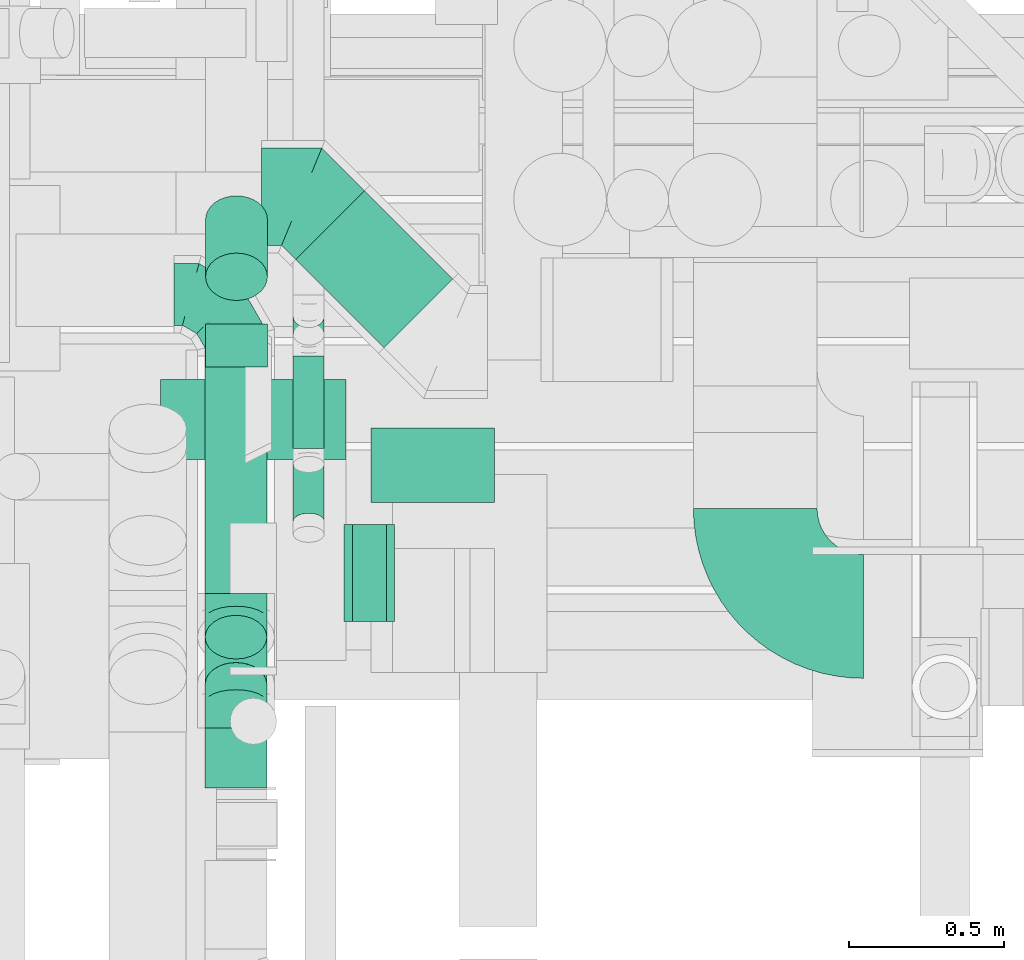
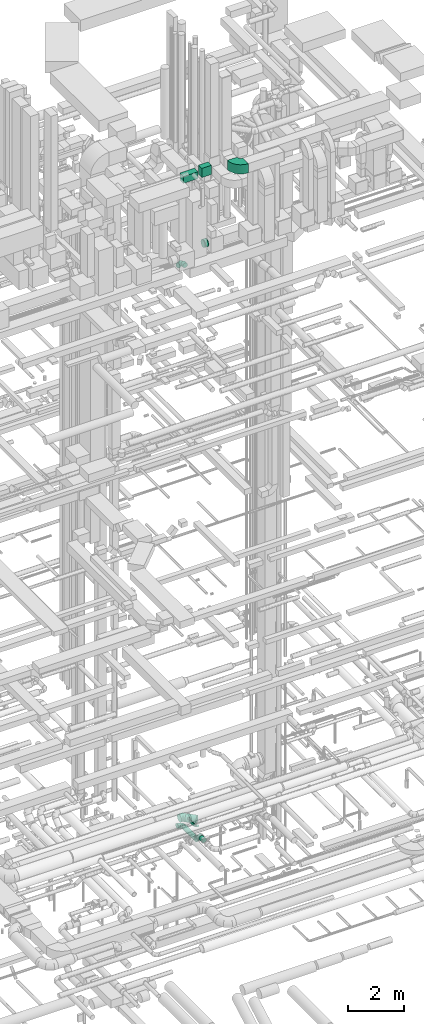
# One storey, part 220 of 337: 12 flow segments, 7 flow fittings.
"""IFC2X3 building model written with IfcOpenShell, lengths in millimetres."""

from ifc_helpers import new_model, entity, si_unit, converted_unit, derived_unit, direction, frame, frame_2d, origin, origin_2d_with_axis, place, context, subcontext, project, spatial, polyline, circle_curve, parameter, trimmed, segment, composite_curve, rectangle, circle, outline, extrude, faceted_brep, source, transform, mapped, material, type_object, type_shapes, element, save


model = new_model("IFC2X3")

# Units and contexts
model_context = context("Model", 3, precision=0.01, world=origin(), true_north=direction((6.12303176911189e-17, 1.0)))
body_context = subcontext(model_context, "Body", "Model", "MODEL_VIEW")
ifc_project = project(units=[si_unit("LENGTHUNIT", "METRE", prefix="MILLI"), si_unit("AREAUNIT", "SQUARE_METRE"), si_unit("VOLUMEUNIT", "CUBIC_METRE"), converted_unit("PLANEANGLEUNIT", "DEGREE", entity("IfcRatioMeasure", 0.0174532925199433), si_unit("PLANEANGLEUNIT", "RADIAN"), dimensions=[0, 0, 0, 0, 0, 0, 0]), si_unit("MASSUNIT", "GRAM", prefix="KILO"), derived_unit("MASSDENSITYUNIT", [(si_unit("MASSUNIT", "GRAM", prefix="KILO"), 1), (si_unit("LENGTHUNIT", "METRE"), -3)]), derived_unit("MOMENTOFINERTIAUNIT", [(si_unit("LENGTHUNIT", "METRE"), 4)]), si_unit("TIMEUNIT", "SECOND"), si_unit("FREQUENCYUNIT", "HERTZ"), si_unit("THERMODYNAMICTEMPERATUREUNIT", "DEGREE_CELSIUS"), derived_unit("THERMALTRANSMITTANCEUNIT", [(si_unit("MASSUNIT", "GRAM", prefix="KILO"), 1), (si_unit("THERMODYNAMICTEMPERATUREUNIT", "KELVIN"), -1), (si_unit("TIMEUNIT", "SECOND"), -3)]), derived_unit("VOLUMETRICFLOWRATEUNIT", [(si_unit("LENGTHUNIT", "METRE"), 3), (si_unit("TIMEUNIT", "SECOND"), -1)]), derived_unit("MASSFLOWRATEUNIT", [(si_unit("MASSUNIT", "GRAM", prefix="KILO"), 1), (si_unit("TIMEUNIT", "SECOND"), -1)]), derived_unit("ROTATIONALFREQUENCYUNIT", [(si_unit("TIMEUNIT", "SECOND"), -1)]), si_unit("ELECTRICCURRENTUNIT", "AMPERE"), si_unit("ELECTRICVOLTAGEUNIT", "VOLT"), si_unit("POWERUNIT", "WATT"), si_unit("FORCEUNIT", "NEWTON", prefix="KILO"), si_unit("ILLUMINANCEUNIT", "LUX"), si_unit("LUMINOUSFLUXUNIT", "LUMEN"), si_unit("LUMINOUSINTENSITYUNIT", "CANDELA"), derived_unit("USERDEFINED", [(si_unit("MASSUNIT", "GRAM", prefix="KILO"), -1), (si_unit("LENGTHUNIT", "METRE"), -2), (si_unit("TIMEUNIT", "SECOND"), 3), (si_unit("LUMINOUSFLUXUNIT", "LUMEN"), 1)]), derived_unit("LINEARVELOCITYUNIT", [(si_unit("LENGTHUNIT", "METRE"), 1), (si_unit("TIMEUNIT", "SECOND"), -1)]), si_unit("PRESSUREUNIT", "PASCAL"), derived_unit("USERDEFINED", [(si_unit("LENGTHUNIT", "METRE"), -2), (si_unit("MASSUNIT", "GRAM", prefix="KILO"), 1), (si_unit("TIMEUNIT", "SECOND"), -2)]), derived_unit("LINEARFORCEUNIT", [(si_unit("MASSUNIT", "GRAM", prefix="KILO"), 1), (si_unit("LENGTHUNIT", "METRE"), 1), (si_unit("TIMEUNIT", "SECOND"), -2), (si_unit("LENGTHUNIT", "METRE"), -1)]), derived_unit("PLANARFORCEUNIT", [(si_unit("MASSUNIT", "GRAM", prefix="KILO"), 1), (si_unit("LENGTHUNIT", "METRE"), 1), (si_unit("TIMEUNIT", "SECOND"), -2), (si_unit("LENGTHUNIT", "METRE"), -2)])], contexts=[model_context])

# Site, building, storey
site_placement = place(None, origin())
site = spatial("IfcSite", under=ifc_project, at=site_placement, CompositionType="ELEMENT")
building_placement = place(site_placement, origin())
building = spatial("IfcBuilding", under=site, at=building_placement, CompositionType="ELEMENT")
storey_placement = place(building_placement, origin())
storey = spatial("IfcBuildingStorey", under=building, at=storey_placement, CompositionType="ELEMENT", Elevation=0.0)

# Flow segments
duct_segment_type_1 = type_object("IfcDuctSegmentType", PredefinedType="NOTDEFINED")
flow_segment_1_placement = place(storey_placement, frame((54088.0, 8895.5, 31400.0)))
element("IfcFlowSegment", 1, at=flow_segment_1_placement, inside=storey, type_object=duct_segment_type_1, context=body_context, shape_type="SweptSolid", body=[
    extrude(rectangle(XDim=260.000000000065, YDim=600.000000000002, at=origin_2d_with_axis()), frame((300.0, 130.0, 0.0), z_axis=(0.0, 0.0, 1.0), x_axis=(0.0, 1.0, 0.0)), (0.0, 0.0, 1.0), 300.000000000001),
])
flow_segment_2_placement = place(storey_placement, frame((54768.0, 8757.5, 31500.0)))
element("IfcFlowSegment", 2, at=flow_segment_2_placement, inside=storey, type_object=duct_segment_type_1, context=body_context, shape_type="SweptSolid", body=[
    extrude(rectangle(XDim=240.500000000089, YDim=399.999999999996, at=origin_2d_with_axis()), frame((200.0, 120.25, 0.0), z_axis=(0.0, 0.0, 1.0), x_axis=(0.0, 1.0, 0.0)), (0.0, 0.0, 1.0), 400.000000000004),
])
duct_segment_type_2 = type_object("IfcDuctSegmentType", PredefinedType="NOTDEFINED")
flow_segment_3_placement = place(storey_placement, frame((54230.32, 8462.9, 2948.4)))
element("IfcFlowSegment", 3, at=flow_segment_3_placement, inside=storey, type_object=duct_segment_type_2, context=body_context, shape_type="SweptSolid", body=[
    extrude(circle(Radius=100.0, at=origin_2d_with_axis()), frame((101.6, 0.0, 101.6), z_axis=(0.0, 1.0, 0.0), x_axis=(-1.0, 0.0, 0.0)), (0.0, 0.0, 1.0), 767.057287525357),
])
flow_segment_4_placement = place(storey_placement, frame((54230.32, 8096.33, 3036.27)))
element("IfcFlowSegment", 4, at=flow_segment_4_placement, inside=storey, type_object=duct_segment_type_2, context=body_context, shape_type="SweptSolid", body=[
    extrude(circle(Radius=100.0, at=origin_2d_with_axis()), frame((101.6, 225.15, 72.31), z_axis=(0.0, -0.707106781186546, 0.707106781186549), x_axis=(-1.0, 0.0, 0.0)), (0.0, 0.0, 1.0), 216.152236891493),
])
flow_segment_5_placement = place(storey_placement, frame((54231.92, 9408.69, 27205.57)))
element("IfcFlowSegment", 5, at=flow_segment_5_placement, inside=storey, type_object=duct_segment_type_2, context=body_context, shape_type="SweptSolid", body=[
    extrude(circle(Radius=100.0, at=origin_2d_with_axis()), frame((101.6, 78.2, 286.65), z_axis=(0.0, 0.642787609686537, -0.76604444311898), x_axis=(-1.0, 0.0, 0.0)), (0.0, 0.0, 1.0), 288.206572271396),
])
flow_segment_6_placement = place(storey_placement, frame((54231.92, 9194.98, 27462.07)))
element("IfcFlowSegment", 6, at=flow_segment_6_placement, inside=storey, type_object=duct_segment_type_2, context=body_context, shape_type="SweptSolid", body=[
    extrude(circle(Radius=100.0, at=origin_2d_with_axis()), frame((101.6, 0.0, 101.6), z_axis=(0.0, 1.0, 0.0), x_axis=(1.0, 0.0, 0.0)), (0.0, 0.0, 1.0), 138.700860216017),
])
flow_segment_7_placement = place(storey_placement, frame((54515.4, 8668.63, 3195.29)))
element("IfcFlowSegment", 7, at=flow_segment_7_placement, inside=storey, type_object=duct_segment_type_2, context=body_context, shape_type="SweptSolid", body=[
    extrude(circle(Radius=50.0, at=origin_2d_with_axis()), frame((51.6, 27.6, 156.26), z_axis=(0.0, 0.854088777418906, -0.520127253936071), x_axis=(1.0, 0.0, 0.0)), (0.0, 0.0, 1.0), 215.250588398526),
])
flow_segment_8_placement = place(storey_placement, frame((54523.65, 9255.18, 2940.91)))
element("IfcFlowSegment", 8, at=flow_segment_8_placement, inside=storey, type_object=duct_segment_type_2, context=body_context, shape_type="SweptSolid", body=[
    extrude(circle(Radius=157.5, at=origin_2d_with_axis()), frame((398.44, 112.96, 159.1), z_axis=(-0.707106781182107, 0.707106781190988, 0.0), x_axis=(-0.707106781190988, -0.707106781182107, 0.0)), (0.0, 0.0, 1.0), 403.72583002495),
])
flow_segment_9_placement = place(storey_placement, frame((54515.4, 8932.09, 3173.4)))
element("IfcFlowSegment", 9, at=flow_segment_9_placement, inside=storey, type_object=duct_segment_type_2, context=body_context, shape_type="SweptSolid", body=[
    extrude(circle(Radius=50.0, at=origin_2d_with_axis()), frame((51.6, 0.0, 51.6), z_axis=(0.0, 1.0, 0.0), x_axis=(1.0, 0.0, 0.0)), (0.0, 0.0, 1.0), 298.546772507563),
])
flow_segment_10_placement = place(storey_placement, frame((54515.4, 9264.39, 3217.34)))
element("IfcFlowSegment", 10, at=flow_segment_10_placement, inside=storey, type_object=duct_segment_type_2, context=body_context, shape_type="SweptSolid", body=[
    extrude(circle(Radius=50.0, at=origin_2d_with_axis()), frame((51.6, 36.95, 36.95), z_axis=(0.0, 0.70710616095761, 0.707107401414941), x_axis=(-1.0, 0.0, 0.0)), (0.0, 0.0, 1.0), 79.7910898784956),
])
flow_segment_11_placement = place(storey_placement, frame((54230.32, 7833.68, 3218.4)))
element("IfcFlowSegment", 11, at=flow_segment_11_placement, inside=storey, type_object=duct_segment_type_2, context=body_context, shape_type="SweptSolid", body=[
    extrude(circle(Radius=100.0, at=origin_2d_with_axis()), frame((101.6, 0.0, 101.6), z_axis=(0.0, 1.0, 0.0), x_axis=(1.0, 0.0, 0.0)), (0.0, 0.0, 1.0), 193.533487977303),
])
flow_segment_12_placement = place(storey_placement, frame((54708.0, 8369.87, 28635.9)))
element("IfcFlowSegment", 12, at=flow_segment_12_placement, inside=storey, type_object=duct_segment_type_2, context=body_context, shape_type="SweptSolid", body=[
    extrude(circle(Radius=157.5, at=origin_2d_with_axis()), frame((0.0, 159.1, 159.1), z_axis=(1.0, 0.0, 0.0), x_axis=(0.0, -1.0, 0.0)), (0.0, 0.0, 1.0), 110.000024999834),
])

# Flow fittings
ifc_material = material()
duct_fitting_type_1 = type_object("IfcDuctFittingType", PredefinedType="NOTDEFINED", material=ifc_material)
shared_shape_1 = source(origin(), body_context, "Body", "Brep", [
    faceted_brep([(-200.0, 0.0, -100.0), (-200.0, -25.88, -96.59), (-200.0, -50.0, -86.6), (-200.0, -70.71, -70.71), (-200.0, -86.6, -50.0), (-200.0, -96.59, -25.88), (-200.0, -100.0, 0.0), (-200.0, -96.59, 25.88), (-200.0, -86.6, 50.0), (-200.0, -70.71, 70.71), (-200.0, -50.0, 86.6), (-200.0, -25.88, 96.59), (-200.0, 0.0, 100.0), (-200.0, 25.88, 96.59), (-200.0, 50.0, 86.6), (-200.0, 70.71, 70.71), (-200.0, 86.6, 50.0), (-200.0, 96.59, 25.88), (-200.0, 100.0, 0.0), (-200.0, 96.59, -25.88), (-200.0, 86.6, -50.0), (-200.0, 70.71, -70.71), (-200.0, 50.0, -86.6), (-200.0, 25.88, -96.59), (-153.35, 25.88, 96.59), (-159.81, 50.0, 86.6), (-146.41, 0.0, 100.0), (-165.36, 70.71, 70.71), (-172.29, 96.59, 25.88), (-173.21, 100.0, 0.0), (-169.62, 86.6, 50.0), (-169.62, 86.6, -50.0), (-165.36, 70.71, -70.71), (-172.29, 96.59, -25.88), (-153.35, 25.88, -96.59), (-146.41, 0.0, -100.0), (-159.81, 50.0, -86.6), (-139.48, -25.88, -96.59), (-133.01, -50.0, -86.6), (-127.46, -70.71, -70.71), (-123.21, -86.6, -50.0), (-120.53, -96.59, -25.88), (-119.62, -100.0, 0.0), (-120.53, -96.59, 25.88), (-123.21, -86.6, 50.0), (-127.46, -70.71, 70.71), (-133.01, -50.0, 86.6), (-139.48, -25.88, 96.59), (-72.54, 72.54, 96.59), (-90.19, 90.19, 86.6), (-53.59, 53.59, 100.0), (-105.35, 105.35, 70.71), (-116.99, 116.99, 50.0), (-124.3, 124.3, 25.88), (-126.79, 126.79, 0.0), (-124.3, 124.3, -25.88), (-116.99, 116.99, -50.0), (-105.35, 105.35, -70.71), (-72.54, 72.54, -96.59), (-53.59, 53.59, -100.0), (-90.19, 90.19, -86.6), (-34.64, 34.64, -96.59), (-16.99, 16.99, -86.6), (-1.83, 1.83, -70.71), (9.81, -9.81, -50.0), (17.12, -17.12, -25.88), (19.62, -19.62, 0.0), (17.12, -17.12, 25.88), (9.81, -9.81, 50.0), (-1.83, 1.83, 70.71), (-16.99, 16.99, 86.6), (-34.64, 34.64, 96.59), (-25.88, 153.35, 96.59), (-50.0, 159.81, 86.6), (0.0, 146.41, 100.0), (-70.71, 165.36, 70.71), (-86.6, 169.62, 50.0), (-96.59, 172.29, 25.88), (-100.0, 173.21, 0.0), (-96.59, 172.29, -25.88), (-86.6, 169.62, -50.0), (-70.71, 165.36, -70.71), (-25.88, 153.35, -96.59), (0.0, 146.41, -100.0), (-50.0, 159.81, -86.6), (25.88, 139.48, -96.59), (50.0, 133.01, -86.6), (70.71, 127.46, -70.71), (86.6, 123.21, -50.0), (96.59, 120.53, -25.88), (100.0, 119.62, 0.0), (96.59, 120.53, 25.88), (86.6, 123.21, 50.0), (70.71, 127.46, 70.71), (50.0, 133.01, 86.6), (25.88, 139.48, 96.59), (-25.88, 200.0, -96.59), (-50.0, 200.0, -86.6), (-70.71, 200.0, -70.71), (-86.6, 200.0, -50.0), (-96.59, 200.0, -25.88), (-100.0, 200.0, 0.0), (-96.59, 200.0, 25.88), (-86.6, 200.0, 50.0), (-70.71, 200.0, 70.71), (-50.0, 200.0, 86.6), (-25.88, 200.0, 96.59), (0.0, 200.0, 100.0), (25.88, 200.0, 96.59), (50.0, 200.0, 86.6), (70.71, 200.0, 70.71), (86.6, 200.0, 50.0), (96.59, 200.0, 25.88), (100.0, 200.0, 0.0), (96.59, 200.0, -25.88), (86.6, 200.0, -50.0), (70.71, 200.0, -70.71), (50.0, 200.0, -86.6), (25.88, 200.0, -96.59), (0.0, 200.0, -100.0)], [[[0, 1, 2, 3, 4, 5, 6, 7, 8, 9, 10, 11, 12, 13, 14, 15, 16, 17, 18, 19, 20, 21, 22, 23]], [[24, 25, 14, 13]], [[26, 24, 13, 12]], [[14, 25, 27, 15]], [[28, 29, 18, 17]], [[30, 28, 17, 16]], [[15, 27, 30, 16]], [[20, 31, 32, 21]], [[33, 31, 20, 19]], [[18, 29, 33, 19]], [[34, 35, 0, 23]], [[36, 34, 23, 22]], [[32, 36, 22, 21]], [[1, 0, 35, 37]], [[2, 1, 37, 38]], [[38, 39, 3, 2]], [[5, 4, 40, 41]], [[6, 5, 41, 42]], [[39, 40, 4, 3]], [[6, 42, 43, 7]], [[7, 43, 44, 8]], [[8, 44, 45, 9]], [[9, 45, 46, 10]], [[10, 46, 47, 11]], [[26, 12, 11, 47]], [[48, 49, 25, 24]], [[50, 48, 24, 26]], [[27, 25, 49, 51]], [[52, 53, 28, 30]], [[51, 52, 30, 27]], [[29, 28, 53, 54]], [[55, 56, 31, 33]], [[54, 55, 33, 29]], [[32, 31, 56, 57]], [[58, 59, 35, 34]], [[60, 58, 34, 36]], [[57, 60, 36, 32]], [[37, 35, 59, 61]], [[38, 37, 61, 62]], [[39, 38, 62, 63]], [[41, 40, 64, 65]], [[42, 41, 65, 66]], [[63, 64, 40, 39]], [[43, 42, 66, 67]], [[44, 43, 67, 68]], [[68, 69, 45, 44]], [[46, 45, 69, 70]], [[47, 46, 70, 71]], [[26, 47, 71, 50]], [[72, 73, 49, 48]], [[74, 72, 48, 50]], [[51, 49, 73, 75]], [[76, 77, 53, 52]], [[75, 76, 52, 51]], [[54, 53, 77, 78]], [[79, 80, 56, 55]], [[78, 79, 55, 54]], [[57, 56, 80, 81]], [[82, 83, 59, 58]], [[84, 82, 58, 60]], [[81, 84, 60, 57]], [[61, 59, 83, 85]], [[62, 61, 85, 86]], [[63, 62, 86, 87]], [[65, 64, 88, 89]], [[66, 65, 89, 90]], [[87, 88, 64, 63]], [[67, 66, 90, 91]], [[68, 67, 91, 92]], [[92, 93, 69, 68]], [[70, 69, 93, 94]], [[71, 70, 94, 95]], [[50, 71, 95, 74]], [[96, 97, 98, 99, 100, 101, 102, 103, 104, 105, 106, 107, 108, 109, 110, 111, 112, 113, 114, 115, 116, 117, 118, 119]], [[72, 74, 107, 106]], [[73, 72, 106, 105]], [[75, 73, 105, 104]], [[102, 101, 78, 77]], [[103, 102, 77, 76]], [[75, 104, 103, 76]], [[78, 101, 100, 79]], [[79, 100, 99, 80]], [[80, 99, 98, 81]], [[84, 97, 96, 82]], [[82, 96, 119, 83]], [[84, 81, 98, 97]], [[118, 117, 86, 85]], [[119, 118, 85, 83]], [[116, 87, 86, 117]], [[88, 115, 114, 89]], [[89, 114, 113, 90]], [[115, 88, 87, 116]], [[91, 90, 113, 112]], [[92, 91, 112, 111]], [[111, 110, 93, 92]], [[95, 94, 109, 108]], [[74, 95, 108, 107]], [[110, 109, 94, 93]]]),
])
type_shapes(duct_fitting_type_1, [shared_shape_1])
flow_fitting_1_placement = place(storey_placement, frame((54331.91, 9429.95, 3050.0), z_axis=(0.0, 0.0, 1.0), x_axis=(0.0, 1.0, 0.0)))
element("IfcFlowFitting", 13, at=flow_fitting_1_placement, inside=storey, type_object=duct_fitting_type_1, material=ifc_material, context=body_context, shape_type="MappedRepresentation", body=[
    mapped(shared_shape_1, transform((0.0, 0.0, 0.0), scale=1.0)),
])
duct_fitting_type_2 = type_object("IfcDuctFittingType", PredefinedType="NOTDEFINED", material=ifc_material)
shared_shape_2 = source(origin(), body_context, "Body", "Brep", [
    faceted_brep([(-82.84, 0.0, -100.0), (-82.84, -25.88, -96.59), (-82.84, -50.0, -86.6), (-82.84, -70.71, -70.71), (-82.84, -86.6, -50.0), (-82.84, -96.59, -25.88), (-82.84, -100.0, 0.0), (-82.84, -96.59, 25.88), (-82.84, -86.6, 50.0), (-82.84, -70.71, 70.71), (-82.84, -50.0, 86.6), (-82.84, -25.88, 96.59), (-82.84, 0.0, 100.0), (-82.84, 25.88, 96.59), (-82.84, 50.0, 86.6), (-82.84, 70.71, 70.71), (-82.84, 86.6, 50.0), (-82.84, 96.59, 25.88), (-82.84, 100.0, 0.0), (-82.84, 96.59, -25.88), (-82.84, 86.6, -50.0), (-82.84, 70.71, -70.71), (-82.84, 50.0, -86.6), (-82.84, 25.88, -96.59), (-10.72, 25.88, 96.59), (-20.71, 50.0, 86.6), (0.0, 0.0, 100.0), (-29.29, 70.71, 70.71), (-35.87, 86.6, 50.0), (-40.01, 96.59, 25.88), (-41.42, 100.0, 0.0), (-40.01, 96.59, -25.88), (-35.87, 86.6, -50.0), (-29.29, 70.71, -70.71), (-10.72, 25.88, -96.59), (0.0, 0.0, -100.0), (-20.71, 50.0, -86.6), (10.72, -25.88, -96.59), (20.71, -50.0, -86.6), (29.29, -70.71, -70.71), (35.87, -86.6, -50.0), (40.01, -96.59, -25.88), (41.42, -100.0, 0.0), (40.01, -96.59, 25.88), (35.87, -86.6, 50.0), (29.29, -70.71, 70.71), (20.71, -50.0, 86.6), (10.72, -25.88, 96.59), (58.58, 58.58, 100.0), (40.28, 76.88, 96.59), (23.22, 93.93, 86.6), (8.58, 108.58, 70.71), (-2.66, 119.82, 50.0), (-9.72, 126.88, 25.88), (-12.13, 129.29, 0.0), (-9.72, 126.88, -25.88), (-2.66, 119.82, -50.0), (8.58, 108.58, -70.71), (23.22, 93.93, -86.6), (40.28, 76.88, -96.59), (58.58, 58.58, -100.0), (76.88, 40.28, -96.59), (93.93, 23.22, -86.6), (108.58, 8.58, -70.71), (119.82, -2.66, -50.0), (126.88, -9.72, -25.88), (129.29, -12.13, 0.0), (126.88, -9.72, 25.88), (119.82, -2.66, 50.0), (108.58, 8.58, 70.71), (93.93, 23.22, 86.6), (76.88, 40.28, 96.59)], [[[0, 1, 2, 3, 4, 5, 6, 7, 8, 9, 10, 11, 12, 13, 14, 15, 16, 17, 18, 19, 20, 21, 22, 23]], [[24, 25, 14, 13]], [[26, 24, 13, 12]], [[14, 25, 27, 15]], [[28, 29, 17, 16]], [[28, 16, 15, 27]], [[30, 18, 17, 29]], [[31, 32, 20, 19]], [[30, 31, 19, 18]], [[32, 33, 21, 20]], [[34, 35, 0, 23]], [[36, 34, 23, 22]], [[33, 36, 22, 21]], [[1, 0, 35, 37]], [[2, 1, 37, 38]], [[38, 39, 3, 2]], [[5, 4, 40, 41]], [[6, 5, 41, 42]], [[39, 40, 4, 3]], [[6, 42, 43, 7]], [[7, 43, 44, 8]], [[8, 44, 45, 9]], [[9, 45, 46, 10]], [[10, 46, 47, 11]], [[26, 12, 11, 47]], [[24, 26, 48, 49]], [[25, 24, 49, 50]], [[27, 25, 50, 51]], [[29, 28, 52, 53]], [[30, 29, 53, 54]], [[51, 52, 28, 27]], [[30, 54, 55, 31]], [[31, 55, 56, 32]], [[57, 33, 32, 56]], [[36, 58, 59, 34]], [[34, 59, 60, 35]], [[58, 36, 33, 57]], [[35, 60, 61, 37]], [[37, 61, 62, 38]], [[63, 39, 38, 62]], [[40, 64, 65, 41]], [[41, 65, 66, 42]], [[64, 40, 39, 63]], [[43, 42, 66, 67]], [[44, 43, 67, 68]], [[68, 69, 45, 44]], [[47, 46, 70, 71]], [[26, 47, 71, 48]], [[69, 70, 46, 45]], [[59, 58, 57, 56, 55, 54, 53, 52, 51, 50, 49, 48, 71, 70, 69, 68, 67, 66, 65, 64, 63, 62, 61, 60]]]),
])
type_shapes(duct_fitting_type_2, [shared_shape_2])
for number, where, z_axis, x_axis in (
    (14, (54331.91, 8380.05, 3050.0), (-1.0, 0.0, 0.0), (0.0, -1.0, 0.0)),
    (15, (54331.91, 8110.05, 3320.0), (1.0, 0.0, 0.0), (0.0, -0.707106781186546, 0.707106781186549)),
):
    element("IfcFlowFitting", number, at=place(storey_placement, frame(where, z_axis=z_axis, x_axis=x_axis)), inside=storey, type_object=duct_fitting_type_2, material=ifc_material, context=body_context, shape_type="MappedRepresentation", body=[
        mapped(shared_shape_2, transform((0.0, 0.0, 0.0), scale=1.0)),
    ])
duct_fitting_type_3 = type_object("IfcDuctFittingType", PredefinedType="NOTDEFINED", material=ifc_material)
shared_shape_3 = source(origin(), body_context, "Body", "Brep", [
    faceted_brep([(20.0, 40.76, -152.13), (20.0, 78.75, -136.4), (20.0, 111.37, -111.37), (20.0, 136.4, -78.75), (20.0, 152.13, -40.76), (20.0, 157.5, 0.0), (20.0, 152.13, 40.76), (20.0, 136.4, 78.75), (20.0, 111.37, 111.37), (20.0, 78.75, 136.4), (20.0, 40.76, 152.13), (20.0, 0.0, 157.5), (20.0, -40.76, 152.13), (20.0, -78.75, 136.4), (20.0, -111.37, 111.37), (20.0, -136.4, 78.75), (20.0, -152.13, 40.76), (20.0, -157.5, 0.0), (20.0, -152.13, -40.76), (20.0, -136.4, -78.75), (20.0, -111.37, -111.37), (20.0, -78.75, -136.4), (20.0, -40.76, -152.13), (20.0, 0.0, -157.5), (0.0, 0.0, 157.5), (0.0, 40.76, 152.13), (-6.1, 40.76, 152.13), (-6.1, 0.0, 157.5), (0.0, 78.75, 136.4), (-6.1, 78.75, 136.4), (0.0, 111.37, 111.37), (-6.1, 111.37, 111.37), (0.0, 136.4, 78.75), (0.0, 152.13, 40.76), (-6.1, 152.13, 40.76), (-6.1, 136.4, 78.75), (0.0, 157.5, 0.0), (-6.1, 157.5, 0.0), (0.0, 152.13, -40.76), (-6.1, 152.13, -40.76), (0.0, 136.4, -78.75), (-6.1, 136.4, -78.75), (0.0, 111.37, -111.37), (-6.1, 111.37, -111.37), (0.0, 0.0, -157.5), (-6.1, 0.0, -157.5), (-6.1, 40.76, -152.13), (0.0, 40.76, -152.13), (-6.1, 78.75, -136.4), (0.0, 78.75, -136.4), (0.0, -40.76, -152.13), (-6.1, -40.76, -152.13), (0.0, -78.75, -136.4), (-6.1, -78.75, -136.4), (0.0, -111.37, -111.37), (-6.1, -111.37, -111.37), (0.0, -136.4, -78.75), (0.0, -152.13, -40.76), (-6.1, -152.13, -40.76), (-6.1, -136.4, -78.75), (0.0, -157.5, 0.0), (-6.1, -157.5, 0.0), (0.0, -152.13, 40.76), (-6.1, -152.13, 40.76), (0.0, -136.4, 78.75), (-6.1, -136.4, 78.75), (0.0, -111.37, 111.37), (-6.1, -111.37, 111.37), (0.0, -78.75, 136.4), (0.0, -40.76, 152.13), (-6.1, -40.76, 152.13), (-6.1, -78.75, 136.4)], [[[0, 1, 2, 3, 4, 5, 6, 7, 8, 9, 10, 11, 12, 13, 14, 15, 16, 17, 18, 19, 20, 21, 22, 23]], [[24, 11, 10, 25, 26, 27]], [[25, 10, 9, 28, 29, 26]], [[28, 9, 8, 30, 31, 29]], [[32, 7, 6, 33, 34, 35]], [[33, 6, 5, 36, 37, 34]], [[30, 8, 7, 32, 35, 31]], [[36, 5, 4, 38, 39, 37]], [[38, 4, 3, 40, 41, 39]], [[40, 3, 2, 42, 43, 41]], [[0, 23, 44, 45, 46, 47]], [[1, 0, 47, 46, 48, 49]], [[49, 48, 43, 42, 2, 1]], [[44, 23, 22, 50, 51, 45]], [[50, 22, 21, 52, 53, 51]], [[52, 21, 20, 54, 55, 53]], [[56, 19, 18, 57, 58, 59]], [[57, 18, 17, 60, 61, 58]], [[54, 20, 19, 56, 59, 55]], [[60, 17, 16, 62, 63, 61]], [[62, 16, 15, 64, 65, 63]], [[64, 15, 14, 66, 67, 65]], [[68, 13, 12, 69, 70, 71]], [[69, 12, 11, 24, 27, 70]], [[66, 14, 13, 68, 71, 67]], [[45, 51, 53, 55, 59, 58, 61, 63, 65, 67, 71, 70, 27, 26, 29, 31, 35, 34, 37, 39, 41, 43, 48, 46]]]),
])
type_shapes(duct_fitting_type_3, [shared_shape_3])
flow_fitting_2_placement = place(storey_placement, frame((54688.0, 8528.96, 28795.0), z_axis=(0.0, -1.0, 0.0), x_axis=(1.0, 0.0, 0.0)))
element("IfcFlowFitting", 16, at=flow_fitting_2_placement, inside=storey, type_object=duct_fitting_type_3, material=ifc_material, context=body_context, shape_type="MappedRepresentation", body=[
    mapped(shared_shape_3, transform((0.0, 0.0, 0.0), scale=1.0)),
])
duct_fitting_type_4 = type_object("IfcDuctFittingType", PredefinedType="NOTDEFINED", material=ifc_material)
shared_shape_4 = source(origin(), body_context, "Body", "Brep", [
    faceted_brep([(-130.48, 0.0, -157.5), (-130.48, -40.76, -152.13), (-130.48, -78.75, -136.4), (-130.48, -111.37, -111.37), (-130.48, -136.4, -78.75), (-130.48, -152.13, -40.76), (-130.48, -157.5, 0.0), (-130.48, -152.13, 40.76), (-130.48, -136.4, 78.75), (-130.48, -111.37, 111.37), (-130.48, -78.75, 136.4), (-130.48, -40.76, 152.13), (-130.48, 0.0, 157.5), (-130.48, 40.76, 152.13), (-130.48, 78.75, 136.4), (-130.48, 111.37, 111.37), (-130.48, 136.4, 78.75), (-130.48, 152.13, 40.76), (-130.48, 157.5, 0.0), (-130.48, 152.13, -40.76), (-130.48, 136.4, -78.75), (-130.48, 111.37, -111.37), (-130.48, 78.75, -136.4), (-130.48, 40.76, -152.13), (-16.89, 40.76, 152.13), (-32.62, 78.75, 136.4), (0.0, 0.0, 157.5), (-46.13, 111.37, 111.37), (-63.02, 152.13, 40.76), (-65.24, 157.5, 0.0), (-56.5, 136.4, 78.75), (-56.5, 136.4, -78.75), (-46.13, 111.37, -111.37), (-63.02, 152.13, -40.76), (-16.89, 40.76, -152.13), (0.0, 0.0, -157.5), (-32.62, 78.75, -136.4), (16.89, -40.76, -152.13), (32.62, -78.75, -136.4), (46.13, -111.37, -111.37), (56.5, -136.4, -78.75), (63.02, -152.13, -40.76), (65.24, -157.5, 0.0), (63.02, -152.13, 40.76), (56.5, -136.4, 78.75), (46.13, -111.37, 111.37), (32.62, -78.75, 136.4), (16.89, -40.76, 152.13), (92.26, 92.26, 157.5), (63.44, 121.09, 152.13), (36.58, 147.95, 136.4), (13.51, 171.01, 111.37), (-4.19, 188.71, 78.75), (-15.31, 199.84, 40.76), (-19.11, 203.63, 0.0), (-15.31, 199.84, -40.76), (-4.19, 188.71, -78.75), (13.51, 171.01, -111.37), (36.58, 147.95, -136.4), (63.44, 121.09, -152.13), (92.26, 92.26, -157.5), (121.09, 63.44, -152.13), (147.95, 36.58, -136.4), (171.01, 13.51, -111.37), (188.71, -4.19, -78.75), (199.84, -15.31, -40.76), (203.63, -19.11, 0.0), (199.84, -15.31, 40.76), (188.71, -4.19, 78.75), (171.01, 13.51, 111.37), (147.95, 36.58, 136.4), (121.09, 63.44, 152.13)], [[[0, 1, 2, 3, 4, 5, 6, 7, 8, 9, 10, 11, 12, 13, 14, 15, 16, 17, 18, 19, 20, 21, 22, 23]], [[24, 25, 14, 13]], [[26, 24, 13, 12]], [[14, 25, 27, 15]], [[28, 29, 18, 17]], [[30, 28, 17, 16]], [[15, 27, 30, 16]], [[20, 31, 32, 21]], [[33, 31, 20, 19]], [[18, 29, 33, 19]], [[34, 35, 0, 23]], [[36, 34, 23, 22]], [[32, 36, 22, 21]], [[1, 0, 35, 37]], [[2, 1, 37, 38]], [[38, 39, 3, 2]], [[5, 4, 40, 41]], [[6, 5, 41, 42]], [[39, 40, 4, 3]], [[6, 42, 43, 7]], [[7, 43, 44, 8]], [[8, 44, 45, 9]], [[9, 45, 46, 10]], [[10, 46, 47, 11]], [[26, 12, 11, 47]], [[24, 26, 48, 49]], [[25, 24, 49, 50]], [[27, 25, 50, 51]], [[28, 30, 52, 53]], [[29, 28, 53, 54]], [[51, 52, 30, 27]], [[55, 56, 31, 33]], [[54, 55, 33, 29]], [[57, 32, 31, 56]], [[36, 58, 59, 34]], [[34, 59, 60, 35]], [[58, 36, 32, 57]], [[35, 60, 61, 37]], [[37, 61, 62, 38]], [[63, 39, 38, 62]], [[40, 64, 65, 41]], [[41, 65, 66, 42]], [[64, 40, 39, 63]], [[43, 42, 66, 67]], [[44, 43, 67, 68]], [[68, 69, 45, 44]], [[47, 46, 70, 71]], [[26, 47, 71, 48]], [[69, 70, 46, 45]], [[54, 53, 52, 51, 50, 49, 48, 71, 70, 69, 68, 67, 66, 65, 64, 63, 62, 61, 60, 59, 58, 57, 56, 55]]]),
])
type_shapes(duct_fitting_type_4, [shared_shape_4])
flow_fitting_3_placement = place(storey_placement, frame((54544.36, 9745.88, 3100.0), z_axis=(-8.92429004970765e-06, -8.92429004970765e-06, 1.0), x_axis=(-0.707106781186548, 0.707106781186548, 0.0)))
element("IfcFlowFitting", 17, at=flow_fitting_3_placement, inside=storey, type_object=duct_fitting_type_4, material=ifc_material, context=body_context, shape_type="MappedRepresentation", body=[
    mapped(shared_shape_4, transform((0.0, 0.0, 0.0), scale=1.0)),
])
duct_fitting_type_5 = type_object("IfcDuctFittingType", PredefinedType="NOTDEFINED", material=ifc_material)
shared_shape_5 = source(origin(), body_context, "Body", "Brep", [
    faceted_brep([(20.0, 0.0, -157.5), (20.0, 40.76, -152.13), (20.0, 78.75, -136.4), (20.0, 111.37, -111.37), (20.0, 136.4, -78.75), (20.0, 152.13, -40.76), (20.0, 157.5, 0.0), (20.0, 152.13, 40.76), (20.0, 136.4, 78.75), (20.0, 111.37, 111.37), (20.0, 78.75, 136.4), (20.0, 40.76, 152.13), (20.0, 0.0, 157.5), (20.0, -40.76, 152.13), (20.0, -78.75, 136.4), (20.0, -111.37, 111.37), (20.0, -136.4, 78.75), (20.0, -152.13, 40.76), (20.0, -157.5, 0.0), (20.0, -152.13, -40.76), (20.0, -136.4, -78.75), (20.0, -111.37, -111.37), (20.0, -78.75, -136.4), (20.0, -40.76, -152.13), (0.0, 0.0, 157.5), (-6.1, 0.0, 157.5), (-6.1, -40.76, 152.13), (0.0, -40.76, 152.13), (-6.1, -78.75, 136.4), (0.0, -78.75, 136.4), (0.0, -111.37, 111.37), (-6.1, -111.37, 111.37), (0.0, -136.4, 78.75), (-6.1, -136.4, 78.75), (-6.1, -152.13, 40.76), (0.0, -152.13, 40.76), (-6.1, -157.5, 0.0), (0.0, -157.5, 0.0), (-6.1, -152.13, -40.76), (0.0, -152.13, -40.76), (-6.1, -136.4, -78.75), (0.0, -136.4, -78.75), (0.0, -111.37, -111.37), (-6.1, -111.37, -111.37), (0.0, 0.0, -157.5), (0.0, -40.76, -152.13), (-6.1, -40.76, -152.13), (-6.1, 0.0, -157.5), (0.0, -78.75, -136.4), (-6.1, -78.75, -136.4), (-6.1, 40.76, -152.13), (0.0, 40.76, -152.13), (-6.1, 78.75, -136.4), (0.0, 78.75, -136.4), (0.0, 111.37, -111.37), (-6.1, 111.37, -111.37), (0.0, 136.4, -78.75), (-6.1, 136.4, -78.75), (-6.1, 152.13, -40.76), (0.0, 152.13, -40.76), (-6.1, 157.5, 0.0), (0.0, 157.5, 0.0), (-6.1, 152.13, 40.76), (0.0, 152.13, 40.76), (-6.1, 136.4, 78.75), (0.0, 136.4, 78.75), (0.0, 111.37, 111.37), (-6.1, 111.37, 111.37), (0.0, 78.75, 136.4), (-6.1, 78.75, 136.4), (-6.1, 40.76, 152.13), (0.0, 40.76, 152.13)], [[[0, 1, 2, 3, 4, 5, 6, 7, 8, 9, 10, 11, 12, 13, 14, 15, 16, 17, 18, 19, 20, 21, 22, 23]], [[13, 12, 24, 25, 26, 27]], [[14, 13, 27, 26, 28, 29]], [[30, 15, 14, 29, 28, 31]], [[17, 16, 32, 33, 34, 35]], [[18, 17, 35, 34, 36, 37]], [[32, 16, 15, 30, 31, 33]], [[19, 18, 37, 36, 38, 39]], [[20, 19, 39, 38, 40, 41]], [[42, 21, 20, 41, 40, 43]], [[44, 0, 23, 45, 46, 47]], [[48, 49, 46, 45, 23, 22]], [[22, 21, 42, 43, 49, 48]], [[1, 0, 44, 47, 50, 51]], [[2, 1, 51, 50, 52, 53]], [[54, 3, 2, 53, 52, 55]], [[5, 4, 56, 57, 58, 59]], [[6, 5, 59, 58, 60, 61]], [[56, 4, 3, 54, 55, 57]], [[7, 6, 61, 60, 62, 63]], [[8, 7, 63, 62, 64, 65]], [[66, 9, 8, 65, 64, 67]], [[11, 10, 68, 69, 70, 71]], [[12, 11, 71, 70, 25, 24]], [[68, 10, 9, 66, 67, 69]], [[46, 49, 43, 40, 38, 36, 34, 33, 31, 28, 26, 25, 70, 69, 67, 64, 62, 60, 58, 57, 55, 52, 50, 47]]]),
])
type_shapes(duct_fitting_type_5, [shared_shape_5])
flow_fitting_4_placement = place(storey_placement, frame((54838.0, 8528.96, 28795.0), z_axis=(0.0, 0.0, -1.0), x_axis=(-1.0, 0.0, 0.0)))
element("IfcFlowFitting", 18, at=flow_fitting_4_placement, inside=storey, type_object=duct_fitting_type_5, material=ifc_material, context=body_context, shape_type="MappedRepresentation", body=[
    mapped(shared_shape_5, transform((0.0, 0.0, 0.0), scale=1.0)),
])
duct_fitting_type_6 = type_object("IfcDuctFittingType", PredefinedType="NOTDEFINED", material=ifc_material)
shared_shape_6 = source(origin(), body_context, "Body", "SweptSolid", [
    extrude(outline(composite_curve([segment(polyline([(-375.0, -175.0), (25.0, -175.0)]), True, "CONTINUOUS"), segment(trimmed(circle_curve(frame_2d((175.0, -175.0), x_axis=(0.0, 1.0)), 150.0), [parameter(0.0)], [parameter(90.0)], True, "PARAMETER"), False, "CONTINUOUS"), segment(polyline([(175.0, -25.0), (175.0, 375.0)]), True, "CONTINUOUS"), segment(trimmed(circle_curve(frame_2d((175.0, -175.0), x_axis=(0.0, 1.0)), 550.0), [parameter(0.0)], [parameter(90.0)], True, "PARAMETER"), True, "CONTINUOUS")], self_intersect=False)), frame((-175.0, 175.0, -200.0), z_axis=(0.0, 0.0, 1.0), x_axis=(-1.0, 0.0, 0.0)), (0.0, 0.0, 1.0), 400.0),
])
type_shapes(duct_fitting_type_6, [shared_shape_6])
flow_fitting_5_placement = place(storey_placement, frame((56011.0, 8388.29, 31700.0), z_axis=(0.0, 0.0, 1.0), x_axis=(0.0, -1.0, 0.0)))
element("IfcFlowFitting", 19, at=flow_fitting_5_placement, inside=storey, type_object=duct_fitting_type_6, material=ifc_material, context=body_context, shape_type="MappedRepresentation", body=[
    mapped(shared_shape_6, transform((0.0, 0.0, 0.0), scale=1.0)),
])

save(model, "model.ifc")
